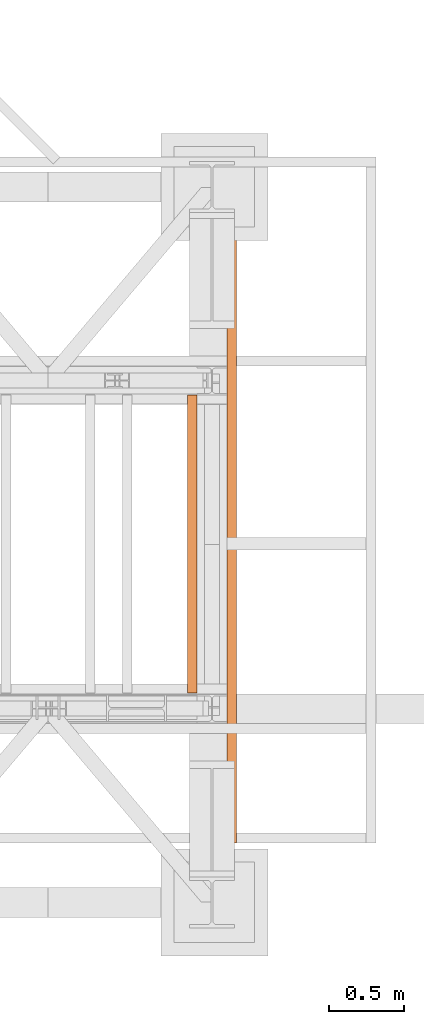
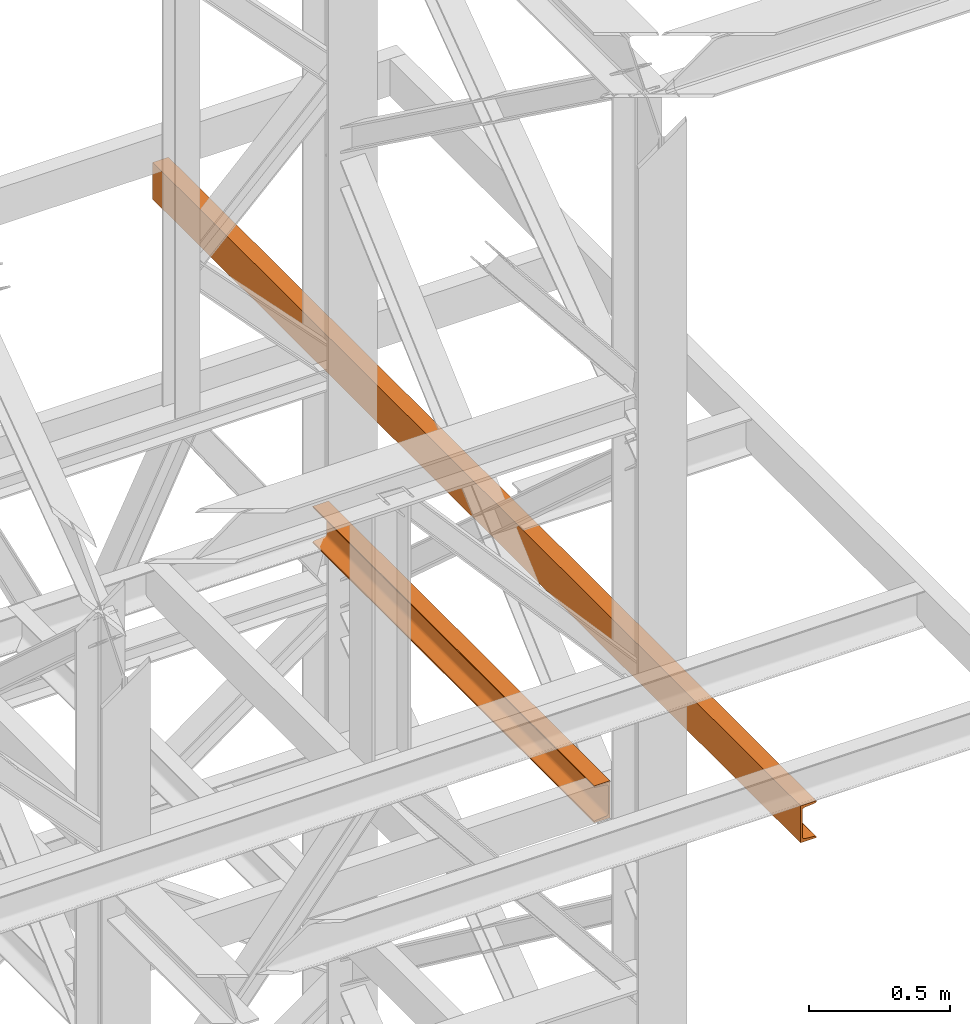
# One storey, part 185 of 208: 2 proxies.
"""IFC2X3 building model written with IfcOpenShell, lengths in millimetres."""

from ifc_helpers import new_model, entity, si_unit, converted_unit, frame, origin, origin_with_axes, place, context, subcontext, project, spatial, faceted_brep, element, save


model = new_model("IFC2X3")

# Units and contexts
model_context = context("Model", 3, precision=1e-05, world=origin())
plan_context = context("Plan", 3, precision=1e-05, world=origin())
body_context = subcontext(model_context, "Body", "Model", "MODEL_VIEW")
ifc_project = project(units=[si_unit("LENGTHUNIT", "METRE", prefix="MILLI"), converted_unit("PLANEANGLEUNIT", "DEGREE", entity("IfcPlaneAngleMeasure", 0.0174532925199433), si_unit("PLANEANGLEUNIT", "RADIAN"), dimensions=[0, 0, 0, 0, 0, 0, 0]), si_unit("AREAUNIT", "SQUARE_METRE"), si_unit("VOLUMEUNIT", "CUBIC_METRE")], contexts=[model_context, plan_context])

# Building, storey
building_placement = place(None, origin())
building = spatial("IfcBuilding", under=ifc_project, at=building_placement, CompositionType="COMPLEX")
storey_placement = place(building_placement, origin_with_axes())
storey = spatial("IfcBuildingStorey", under=building, at=storey_placement, Name="Geschoss", CompositionType="ELEMENT")

# Proxies
proxy_1_placement = place(storey_placement, frame((8893.254970018783, -16862.574391808, 9539.99), z_axis=(0.0, 0.0, 1.0), x_axis=(1.0, 0.0, 0.0)))
element("IfcBuildingElementProxy", 1, at=proxy_1_placement, inside=storey, context=body_context, shape_type="Brep", body=[
    faceted_brep([(65.01000000000022, 4600.010002980231, 0.01000000000021828), (65.01000000000022, 0.01000000000203727, 0.01000000000021828), (65.01000000000022, 0.01000000000203727, 3.132428070246533), (65.01000000000022, 4600.010002980231, 3.132428070246533), (65.01000000000022, 4600.010002980231, 3.132428070246533), (65.01000000000022, 0.01000000000203727, 3.132428070246533), (64.76726342282564, 0.01000000000203727, 4.748288908171162), (64.76726342282564, 4600.010002980231, 4.748288908171162), (64.76726342282564, 4600.010002980231, 4.748288908171162), (64.76726342282564, 0.01000000000203727, 4.748288908171162), (64.06053228585552, 0.01000000000203727, 6.221534443444398), (64.06053228585552, 4600.010002980231, 6.221534443444398), (64.06053228585552, 4600.010002980231, 6.221534443444398), (64.06053228585552, 0.01000000000203727, 6.221534443444398), (62.95215163846842, 0.01000000000203727, 7.422126703873801), (62.95215163846842, 4600.010002980231, 7.422126703873801), (62.95215163846842, 4600.010002980231, 7.422126703873801), (62.95215163846842, 0.01000000000203727, 7.422126703873801), (61.53995641148322, 0.01000000000203727, 8.244091391710754), (61.53995641148504, 4600.010002980231, 8.244091391710754), (61.53995641148504, 4600.010002980231, 8.244091391710754), (61.53995641148322, 0.01000000000203727, 8.244091391710754), (59.94859872255438, 0.01000000000203727, 8.614912102195376), (59.9485987225562, 4600.010002980231, 8.614912102195376), (59.9485987225562, 4600.010002980231, 8.614912102195376), (59.94859872255438, 0.01000000000203727, 8.614912102195376), (17.17267516602988, 0.01000000000203727, 12.0369859867169), (17.17267516602988, 4600.010002980231, 12.0369859867169), (17.17267516602988, 4600.010002980231, 12.0369859867169), (17.17267516602988, 0.01000000000203727, 12.0369859867169), (14.13462866898226, 0.01000000000203727, 12.74491643400506), (14.13462866898408, 4600.010002980231, 12.74491643400506), (14.13462866898408, 4600.010002980231, 12.74491643400506), (14.13462866898226, 0.01000000000203727, 12.74491643400506), (11.43861959928654, 0.01000000000203727, 14.31412174714933), (11.43861959928654, 4600.010002980231, 14.31412174714933), (11.43861959928654, 4600.010002980231, 14.31412174714933), (11.43861959928654, 0.01000000000203727, 14.31412174714933), (9.322620181546881, 0.01000000000203727, 16.60616151705835), (9.322620181546881, 4600.010002980231, 16.60616151705835), (9.322620181546881, 4600.010002980231, 16.60616151705835), (9.322620181546881, 0.01000000000203727, 16.60616151705835), (7.973406192784751, 0.01000000000203727, 19.41872117530875), (7.97340619278657, 4600.010002980231, 19.41872117530875), (7.97340619278657, 4600.010002980231, 19.41872117530875), (7.973406192784751, 0.01000000000203727, 19.41872117530875), (7.510000000000218, 0.01000000000203727, 22.50354641134618), (7.510000000000218, 4600.010002980231, 22.50354641134618), (7.510000000000218, 4600.010002980231, 22.50354641134618), (7.510000000000218, 0.01000000000203727, 22.50354641134618), (7.510000000000218, 0.01000000000203727, 137.5164535886524), (7.510000000000218, 4600.010002980231, 137.5164535886524), (7.510000000000218, 4600.010002980231, 137.5164535886524), (7.510000000000218, 0.01000000000203727, 137.5164535886524), (7.973406192784751, 0.01000000000203727, 140.6012788246917), (7.973406192784751, 4600.010002980231, 140.6012788246917), (7.973406192784751, 4600.010002980231, 140.6012788246917), (7.973406192784751, 0.01000000000203727, 140.6012788246917), (9.322620181546881, 0.01000000000203727, 143.4138384829403), (9.322620181546881, 4600.010002980231, 143.4138384829403), (9.322620181546881, 4600.010002980231, 143.4138384829403), (9.322620181546881, 0.01000000000203727, 143.4138384829403), (11.43861959928654, 0.01000000000203727, 145.7058782528493), (11.43861959928654, 4600.010002980231, 145.7058782528493), (11.43861959928654, 4600.010002980231, 145.7058782528493), (11.43861959928654, 0.01000000000203727, 145.7058782528493), (14.13462866898226, 0.01000000000203727, 147.2750835659936), (14.13462866898408, 4600.010002980231, 147.2750835659936), (14.13462866898408, 4600.010002980231, 147.2750835659936), (14.13462866898226, 0.01000000000203727, 147.2750835659936), (17.17267516602988, 0.01000000000203727, 147.9830140132817), (17.17267516602988, 4600.010002980231, 147.9830140132817), (17.17267516602988, 4600.010002980231, 147.9830140132817), (17.17267516602988, 0.01000000000203727, 147.9830140132817), (59.94859872255438, 0.01000000000203727, 151.4050878978032), (59.9485987225562, 4600.010002980231, 151.4050878978032), (59.9485987225562, 4600.010002980231, 151.4050878978032), (59.94859872255438, 0.01000000000203727, 151.4050878978032), (61.53995641148322, 0.01000000000203727, 151.7759086082879), (61.53995641148504, 4600.010002980231, 151.7759086082879), (61.53995641148504, 4600.010002980231, 151.7759086082879), (61.53995641148322, 0.01000000000203727, 151.7759086082879), (62.95215163846842, 0.01000000000203727, 152.5978732961248), (62.95215163846842, 4600.010002980231, 152.5978732961248), (62.95215163846842, 4600.010002980231, 152.5978732961248), (62.95215163846842, 0.01000000000203727, 152.5978732961248), (64.06053228585552, 0.01000000000203727, 153.7984655565542), (64.06053228585552, 4600.010002980231, 153.7984655565542), (64.06053228585552, 4600.010002980231, 153.7984655565542), (64.06053228585552, 0.01000000000203727, 153.7984655565542), (64.76726342282564, 0.01000000000203727, 155.2717110918275), (64.76726342282564, 4600.010002980231, 155.2717110918275), (64.76726342282564, 4600.010002980231, 155.2717110918275), (64.76726342282564, 0.01000000000203727, 155.2717110918275), (65.01000000000022, 0.01000000000203727, 156.8875719297521), (65.01000000000022, 4600.010002980231, 156.8875719297521), (65.01000000000022, 4600.010002980231, 156.8875719297521), (65.01000000000022, 0.01000000000203727, 156.8875719297521), (65.01000000000022, 0.01000000000203727, 160.0100000000002), (65.01000000000022, 4600.010002980231, 160.0100000000002), (65.01000000000022, 4600.010002980231, 160.0100000000002), (65.01000000000022, 0.01000000000203727, 160.0100000000002), (0.01000000000021828, 0.01000000000203727, 160.0100000000002), (0.01000000000021828, 4600.010002980231, 160.0100000000002), (0.01000000000021828, 4600.010002980231, 160.0100000000002), (0.01000000000021828, 0.01000000000203727, 160.0100000000002), (0.01000000000021828, 0.01000000000203727, 0.01000000000021828), (0.01000000000021828, 4600.010002980231, 0.01000000000021828), (0.01000000000021828, 4600.010002980231, 0.01000000000021828), (0.01000000000021828, 0.01000000000203727, 0.01000000000021828), (65.01000000000022, 0.01000000000203727, 0.01000000000021828), (65.01000000000022, 4600.010002980231, 0.01000000000021828), (65.01000000000022, 4600.010002980231, 0.01000000000021828), (65.01000000000022, 4600.010002980231, 3.132428070246533), (64.76726342282564, 4600.010002980231, 4.748288908171162), (64.06053228585552, 4600.010002980231, 6.221534443444398), (62.95215163846842, 4600.010002980231, 7.422126703873801), (61.53995641148504, 4600.010002980231, 8.244091391710754), (59.9485987225562, 4600.010002980231, 8.614912102195376), (17.17267516602988, 4600.010002980231, 12.0369859867169), (14.13462866898408, 4600.010002980231, 12.74491643400506), (11.43861959928654, 4600.010002980231, 14.31412174714933), (9.322620181546881, 4600.010002980231, 16.60616151705835), (7.97340619278657, 4600.010002980231, 19.41872117530875), (7.510000000000218, 4600.010002980231, 22.50354641134618), (7.510000000000218, 4600.010002980231, 137.5164535886524), (7.973406192784751, 4600.010002980231, 140.6012788246917), (9.322620181546881, 4600.010002980231, 143.4138384829403), (11.43861959928654, 4600.010002980231, 145.7058782528493), (14.13462866898408, 4600.010002980231, 147.2750835659936), (17.17267516602988, 4600.010002980231, 147.9830140132817), (59.9485987225562, 4600.010002980231, 151.4050878978032), (61.53995641148504, 4600.010002980231, 151.7759086082879), (62.95215163846842, 4600.010002980231, 152.5978732961248), (64.06053228585552, 4600.010002980231, 153.7984655565542), (64.76726342282564, 4600.010002980231, 155.2717110918275), (65.01000000000022, 4600.010002980231, 156.8875719297521), (65.01000000000022, 4600.010002980231, 160.0100000000002), (0.01000000000021828, 4600.010002980231, 160.0100000000002), (0.01000000000021828, 4600.010002980231, 0.01000000000021828), (65.01000000000022, 0.01000000000203727, 0.01000000000021828), (0.01000000000021828, 0.01000000000203727, 0.01000000000021828), (0.01000000000021828, 0.01000000000203727, 160.0100000000002), (65.01000000000022, 0.01000000000203727, 160.0100000000002), (65.01000000000022, 0.01000000000203727, 156.8875719297521), (64.76726342282564, 0.01000000000203727, 155.2717110918275), (64.06053228585552, 0.01000000000203727, 153.7984655565542), (62.95215163846842, 0.01000000000203727, 152.5978732961248), (61.53995641148322, 0.01000000000203727, 151.7759086082879), (59.94859872255438, 0.01000000000203727, 151.4050878978032), (17.17267516602988, 0.01000000000203727, 147.9830140132817), (14.13462866898226, 0.01000000000203727, 147.2750835659936), (11.43861959928654, 0.01000000000203727, 145.7058782528493), (9.322620181546881, 0.01000000000203727, 143.4138384829403), (7.973406192784751, 0.01000000000203727, 140.6012788246917), (7.510000000000218, 0.01000000000203727, 137.5164535886524), (7.510000000000218, 0.01000000000203727, 22.50354641134618), (7.973406192784751, 0.01000000000203727, 19.41872117530875), (9.322620181546881, 0.01000000000203727, 16.60616151705835), (11.43861959928654, 0.01000000000203727, 14.31412174714933), (14.13462866898226, 0.01000000000203727, 12.74491643400506), (17.17267516602988, 0.01000000000203727, 12.0369859867169), (59.94859872255438, 0.01000000000203727, 8.614912102195376), (61.53995641148322, 0.01000000000203727, 8.244091391710754), (62.95215163846842, 0.01000000000203727, 7.422126703873801), (64.06053228585552, 0.01000000000203727, 6.221534443444398), (64.76726342282564, 0.01000000000203727, 4.748288908171162), (65.01000000000022, 0.01000000000203727, 3.132428070246533)], [[[0, 1, 2, 3]], [[4, 5, 6, 7]], [[8, 9, 10, 11]], [[12, 13, 14, 15]], [[16, 17, 18, 19]], [[20, 21, 22, 23]], [[24, 25, 26, 27]], [[28, 29, 30, 31]], [[32, 33, 34, 35]], [[36, 37, 38, 39]], [[40, 41, 42, 43]], [[44, 45, 46, 47]], [[48, 49, 50, 51]], [[52, 53, 54, 55]], [[56, 57, 58, 59]], [[60, 61, 62, 63]], [[64, 65, 66, 67]], [[68, 69, 70, 71]], [[72, 73, 74, 75]], [[76, 77, 78, 79]], [[80, 81, 82, 83]], [[84, 85, 86, 87]], [[88, 89, 90, 91]], [[92, 93, 94, 95]], [[96, 97, 98, 99]], [[100, 101, 102, 103]], [[104, 105, 106, 107]], [[108, 109, 110, 111]], [[112, 113, 114, 115, 116, 117, 118, 119, 120, 121, 122, 123, 124, 125, 126, 127, 128, 129, 130, 131, 132, 133, 134, 135, 136, 137, 138, 139]], [[140, 141, 142, 143, 144, 145, 146, 147, 148, 149, 150, 151, 152, 153, 154, 155, 156, 157, 158, 159, 160, 161, 162, 163, 164, 165, 166, 167]]], orient=[[False], [False], [False], [False], [False], [False], [False], [False], [False], [False], [False], [False], [False], [False], [False], [False], [False], [False], [False], [False], [False], [False], [False], [False], [False], [False], [False], [False], [False], [False]]),
])
proxy_2_placement = place(storey_placement, frame((8628.25496703855, -15857.57439274273, 9109.989999999998), z_axis=(0.0, 0.0, 1.0), x_axis=(1.0, 0.0, 0.0)))
element("IfcBuildingElementProxy", 2, at=proxy_2_placement, inside=storey, context=body_context, shape_type="Brep", body=[
    faceted_brep([(65.01000000000022, 2000.009997019768, 160.0100000000002), (65.01000000000204, 0.01000000000021828, 160.0100000000002), (0.01000000000203727, 0.01000000000021828, 160.0100000000002), (0.01000000000021828, 2000.009997019768, 160.0100000000002), (0.01000000000021828, 2000.009997019768, 160.0100000000002), (0.01000000000203727, 0.01000000000021828, 160.0100000000002), (0.01000000000203727, 0.01000000000021828, 156.8875719297539), (0.01000000000021828, 2000.009997019768, 156.8875719297539), (0.01000000000021828, 2000.009997019768, 156.8875719297539), (0.01000000000203727, 0.01000000000021828, 156.8875719297539), (0.2527365771748009, 0.01000000000021828, 155.2717110918293), (0.2527365771729819, 2000.009997019768, 155.2717110918293), (0.2527365771729819, 2000.009997019768, 155.2717110918293), (0.2527365771748009, 0.01000000000021828, 155.2717110918293), (0.9594677141431021, 0.01000000000021828, 153.7984655565542), (0.959467714144921, 2000.009997019768, 153.7984655565542), (0.959467714144921, 2000.009997019768, 153.7984655565542), (0.9594677141431021, 0.01000000000021828, 153.7984655565542), (2.067848361533834, 0.01000000000021828, 152.5978732961266), (2.067848361532015, 2000.009997019768, 152.5978732961266), (2.067848361532015, 2000.009997019768, 152.5978732961266), (2.067848361533834, 0.01000000000021828, 152.5978732961266), (3.480043588519038, 0.01000000000021828, 151.7759086082897), (3.480043588517219, 2000.009997019768, 151.7759086082897), (3.480043588517219, 2000.009997019768, 151.7759086082897), (3.480043588519038, 0.01000000000021828, 151.7759086082897), (5.071401277447876, 0.01000000000021828, 151.4050878978051), (5.071401277446057, 2000.009997019768, 151.4050878978051), (5.071401277446057, 2000.009997019768, 151.4050878978051), (5.071401277447876, 0.01000000000021828, 151.4050878978051), (47.84732483397238, 0.01000000000021828, 147.9830140132835), (47.84732483397056, 2000.009997019768, 147.9830140132835), (47.84732483397056, 2000.009997019768, 147.9830140132835), (47.84732483397238, 0.01000000000021828, 147.9830140132835), (50.81159179199312, 0.01000000000021828, 147.318026761528), (50.8115917919913, 2000.009997019768, 147.318026761528), (50.8115917919913, 2000.009997019768, 147.318026761528), (50.81159179199312, 0.01000000000021828, 147.318026761528), (53.58138040071208, 0.01000000000021828, 145.7058782528511), (53.5813804007139, 2000.009997019768, 145.7058782528511), (53.5813804007139, 2000.009997019768, 145.7058782528511), (53.58138040071208, 0.01000000000021828, 145.7058782528511), (55.69737981845537, 0.01000000000021828, 143.4138384829421), (55.69737981845356, 2000.009997019768, 143.4138384829421), (55.69737981845356, 2000.009997019768, 143.4138384829421), (55.69737981845537, 0.01000000000021828, 143.4138384829421), (57.04659380721569, 0.01000000000021828, 140.6012788246917), (57.04659380721387, 2000.009997019768, 140.6012788246917), (57.04659380721387, 2000.009997019768, 140.6012788246917), (57.04659380721569, 0.01000000000021828, 140.6012788246917), (57.51000000000204, 0.01000000000021828, 137.5164535886543), (57.51000000000022, 2000.009997019768, 137.5164535886543), (57.51000000000022, 2000.009997019768, 137.5164535886543), (57.51000000000204, 0.01000000000021828, 137.5164535886543), (57.51000000000204, 0.01000000000021828, 22.503546411348), (57.51000000000022, 2000.009997019768, 22.503546411348), (57.51000000000022, 2000.009997019768, 22.503546411348), (57.51000000000204, 0.01000000000021828, 22.503546411348), (57.04659380721569, 0.01000000000021828, 19.41872117530875), (57.04659380721387, 2000.009997019768, 19.41872117530875), (57.04659380721387, 2000.009997019768, 19.41872117530875), (57.04659380721569, 0.01000000000021828, 19.41872117530875), (55.69737981845537, 0.01000000000021828, 16.60616151705835), (55.69737981845356, 2000.009997019768, 16.60616151705835), (55.69737981845356, 2000.009997019768, 16.60616151705835), (55.69737981845537, 0.01000000000021828, 16.60616151705835), (53.58138040071208, 0.01000000000021828, 14.31412174714933), (53.5813804007139, 2000.009997019768, 14.31412174714933), (53.5813804007139, 2000.009997019768, 14.31412174714933), (53.58138040071208, 0.01000000000021828, 14.31412174714933), (50.88537133101636, 0.01000000000021828, 12.74491643400688), (50.88537133101818, 2000.009997019768, 12.74491643400688), (50.88537133101818, 2000.009997019768, 12.74491643400688), (50.88537133101636, 0.01000000000021828, 12.74491643400688), (47.84732483397238, 0.01000000000021828, 12.03698598671872), (47.84732483397056, 2000.009997019768, 12.03698598671872), (47.84732483397056, 2000.009997019768, 12.03698598671872), (47.84732483397238, 0.01000000000021828, 12.03698598671872), (5.071401277447876, 0.01000000000021828, 8.614912102195376), (5.071401277446057, 2000.009997019768, 8.614912102195376), (5.071401277446057, 2000.009997019768, 8.614912102195376), (5.071401277447876, 0.01000000000021828, 8.614912102195376), (3.480043588519038, 0.01000000000021828, 8.244091391710754), (3.480043588517219, 2000.009997019768, 8.244091391710754), (3.480043588517219, 2000.009997019768, 8.244091391710754), (3.480043588519038, 0.01000000000021828, 8.244091391710754), (2.067848361533834, 0.01000000000021828, 7.422126703873801), (2.067848361532015, 2000.009997019768, 7.422126703873801), (2.067848361532015, 2000.009997019768, 7.422126703873801), (2.067848361533834, 0.01000000000021828, 7.422126703873801), (0.9594677141431021, 0.01000000000021828, 6.221534443446217), (0.959467714144921, 2000.009997019768, 6.221534443446217), (0.959467714144921, 2000.009997019768, 6.221534443446217), (0.9594677141431021, 0.01000000000021828, 6.221534443446217), (0.2527365771748009, 0.01000000000021828, 4.748288908172981), (0.2527365771729819, 2000.009997019768, 4.748288908172981), (0.2527365771729819, 2000.009997019768, 4.748288908172981), (0.2527365771748009, 0.01000000000021828, 4.748288908172981), (0.01000000000203727, 0.01000000000021828, 0.01000000000021828), (0.01000000000021828, 2000.009997019768, 0.01000000000021828), (0.01000000000021828, 2000.009997019768, 0.01000000000021828), (0.01000000000203727, 0.01000000000021828, 0.01000000000021828), (65.01000000000204, 0.01000000000021828, 0.01000000000021828), (65.01000000000022, 2000.009997019768, 0.01000000000021828), (65.01000000000022, 2000.009997019768, 0.01000000000021828), (65.01000000000204, 0.01000000000021828, 0.01000000000021828), (65.01000000000204, 0.01000000000021828, 160.0100000000002), (65.01000000000022, 2000.009997019768, 160.0100000000002), (65.01000000000022, 2000.009997019768, 160.0100000000002), (0.01000000000021828, 2000.009997019768, 160.0100000000002), (0.01000000000021828, 2000.009997019768, 156.8875719297539), (0.2527365771729819, 2000.009997019768, 155.2717110918293), (0.959467714144921, 2000.009997019768, 153.7984655565542), (2.067848361532015, 2000.009997019768, 152.5978732961266), (3.480043588517219, 2000.009997019768, 151.7759086082897), (5.071401277446057, 2000.009997019768, 151.4050878978051), (47.84732483397056, 2000.009997019768, 147.9830140132835), (50.8115917919913, 2000.009997019768, 147.318026761528), (53.5813804007139, 2000.009997019768, 145.7058782528511), (55.69737981845356, 2000.009997019768, 143.4138384829421), (57.04659380721387, 2000.009997019768, 140.6012788246917), (57.51000000000022, 2000.009997019768, 137.5164535886543), (57.51000000000022, 2000.009997019768, 22.503546411348), (57.04659380721387, 2000.009997019768, 19.41872117530875), (55.69737981845356, 2000.009997019768, 16.60616151705835), (53.5813804007139, 2000.009997019768, 14.31412174714933), (50.88537133101818, 2000.009997019768, 12.74491643400688), (47.84732483397056, 2000.009997019768, 12.03698598671872), (5.071401277446057, 2000.009997019768, 8.614912102195376), (3.480043588517219, 2000.009997019768, 8.244091391710754), (2.067848361532015, 2000.009997019768, 7.422126703873801), (0.959467714144921, 2000.009997019768, 6.221534443446217), (0.2527365771729819, 2000.009997019768, 4.748288908172981), (0.01000000000021828, 2000.009997019768, 0.01000000000021828), (65.01000000000022, 2000.009997019768, 0.01000000000021828), (65.01000000000204, 0.01000000000021828, 160.0100000000002), (65.01000000000204, 0.01000000000021828, 0.01000000000021828), (0.01000000000203727, 0.01000000000021828, 0.01000000000021828), (0.2527365771748009, 0.01000000000021828, 4.748288908172981), (0.9594677141431021, 0.01000000000021828, 6.221534443446217), (2.067848361533834, 0.01000000000021828, 7.422126703873801), (3.480043588519038, 0.01000000000021828, 8.244091391710754), (5.071401277447876, 0.01000000000021828, 8.614912102195376), (47.84732483397238, 0.01000000000021828, 12.03698598671872), (50.88537133101636, 0.01000000000021828, 12.74491643400688), (53.58138040071208, 0.01000000000021828, 14.31412174714933), (55.69737981845537, 0.01000000000021828, 16.60616151705835), (57.04659380721569, 0.01000000000021828, 19.41872117530875), (57.51000000000204, 0.01000000000021828, 22.503546411348), (57.51000000000204, 0.01000000000021828, 137.5164535886543), (57.04659380721569, 0.01000000000021828, 140.6012788246917), (55.69737981845537, 0.01000000000021828, 143.4138384829421), (53.58138040071208, 0.01000000000021828, 145.7058782528511), (50.81159179199312, 0.01000000000021828, 147.318026761528), (47.84732483397238, 0.01000000000021828, 147.9830140132835), (5.071401277447876, 0.01000000000021828, 151.4050878978051), (3.480043588519038, 0.01000000000021828, 151.7759086082897), (2.067848361533834, 0.01000000000021828, 152.5978732961266), (0.9594677141431021, 0.01000000000021828, 153.7984655565542), (0.2527365771748009, 0.01000000000021828, 155.2717110918293), (0.01000000000203727, 0.01000000000021828, 156.8875719297539), (0.01000000000203727, 0.01000000000021828, 160.0100000000002)], [[[0, 1, 2, 3]], [[4, 5, 6, 7]], [[8, 9, 10, 11]], [[12, 13, 14, 15]], [[16, 17, 18, 19]], [[20, 21, 22, 23]], [[24, 25, 26, 27]], [[28, 29, 30, 31]], [[32, 33, 34, 35]], [[36, 37, 38, 39]], [[40, 41, 42, 43]], [[44, 45, 46, 47]], [[48, 49, 50, 51]], [[52, 53, 54, 55]], [[56, 57, 58, 59]], [[60, 61, 62, 63]], [[64, 65, 66, 67]], [[68, 69, 70, 71]], [[72, 73, 74, 75]], [[76, 77, 78, 79]], [[80, 81, 82, 83]], [[84, 85, 86, 87]], [[88, 89, 90, 91]], [[92, 93, 94, 95]], [[96, 97, 98, 99]], [[100, 101, 102, 103]], [[104, 105, 106, 107]], [[108, 109, 110, 111, 112, 113, 114, 115, 116, 117, 118, 119, 120, 121, 122, 123, 124, 125, 126, 127, 128, 129, 130, 131, 132, 133, 134]], [[135, 136, 137, 138, 139, 140, 141, 142, 143, 144, 145, 146, 147, 148, 149, 150, 151, 152, 153, 154, 155, 156, 157, 158, 159, 160, 161]]], orient=[[False], [False], [False], [False], [False], [False], [False], [False], [False], [False], [False], [False], [False], [False], [False], [False], [False], [False], [False], [False], [False], [False], [False], [False], [False], [False], [False], [False], [False]]),
])

save(model, "model.ifc")
